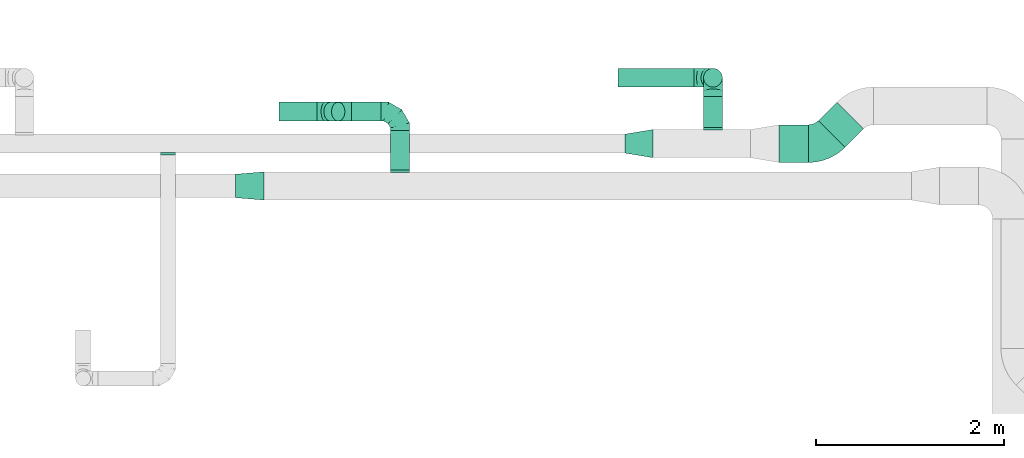
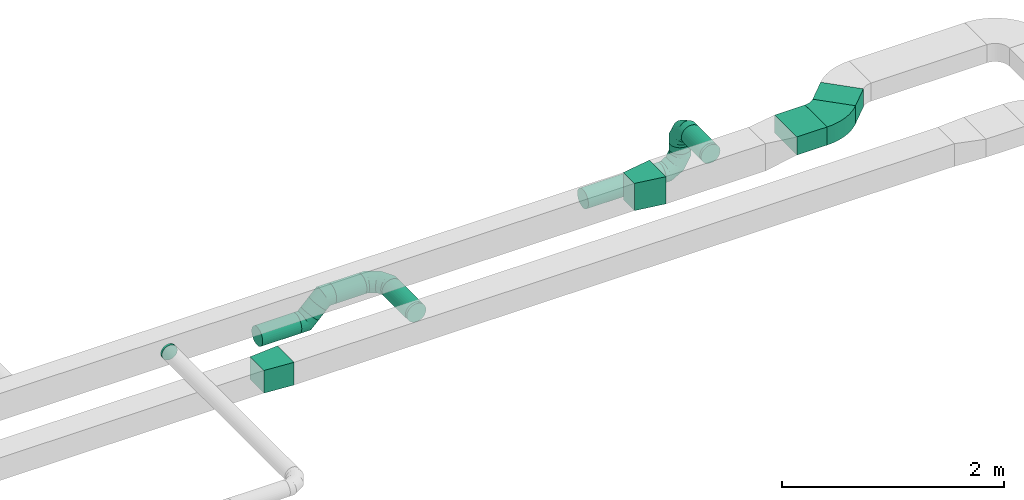
# One storey, part 47 of 60: 11 flow fittings, 9 flow segments.
"""IFC2X3 building model written with IfcOpenShell, lengths in millimetres."""

from ifc_helpers import new_model, entity, si_unit, converted_unit, derived_unit, direction, frame, frame_2d, origin, origin_2d_with_axis, place, context, subcontext, project, spatial, polyline, circle_curve, parameter, trimmed, segment, composite_curve, rectangle, circle, outline, extrude, faceted_brep, source, transform, mapped, material, type_object, type_shapes, element, save


model = new_model("IFC2X3")

# Units and contexts
model_context = context("Model", 3, precision=0.01, world=origin(), true_north=direction((6.12303176911189e-17, 1.0)))
body_context = subcontext(model_context, "Body", "Model", "MODEL_VIEW")
ifc_project = project(units=[si_unit("LENGTHUNIT", "METRE", prefix="MILLI"), si_unit("AREAUNIT", "SQUARE_METRE"), si_unit("VOLUMEUNIT", "CUBIC_METRE"), converted_unit("PLANEANGLEUNIT", "DEGREE", entity("IfcRatioMeasure", 0.0174532925199433), si_unit("PLANEANGLEUNIT", "RADIAN"), dimensions=[0, 0, 0, 0, 0, 0, 0]), si_unit("MASSUNIT", "GRAM", prefix="KILO"), derived_unit("MASSDENSITYUNIT", [(si_unit("MASSUNIT", "GRAM", prefix="KILO"), 1), (si_unit("LENGTHUNIT", "METRE"), -3)]), derived_unit("MOMENTOFINERTIAUNIT", [(si_unit("LENGTHUNIT", "METRE"), 4)]), si_unit("TIMEUNIT", "SECOND"), si_unit("FREQUENCYUNIT", "HERTZ"), si_unit("THERMODYNAMICTEMPERATUREUNIT", "DEGREE_CELSIUS"), derived_unit("THERMALTRANSMITTANCEUNIT", [(si_unit("MASSUNIT", "GRAM", prefix="KILO"), 1), (si_unit("THERMODYNAMICTEMPERATUREUNIT", "KELVIN"), -1), (si_unit("TIMEUNIT", "SECOND"), -3)]), derived_unit("VOLUMETRICFLOWRATEUNIT", [(si_unit("LENGTHUNIT", "METRE"), 3), (si_unit("TIMEUNIT", "SECOND"), -1)]), derived_unit("MASSFLOWRATEUNIT", [(si_unit("MASSUNIT", "GRAM", prefix="KILO"), 1), (si_unit("TIMEUNIT", "SECOND"), -1)]), derived_unit("ROTATIONALFREQUENCYUNIT", [(si_unit("TIMEUNIT", "SECOND"), -1)]), si_unit("ELECTRICCURRENTUNIT", "AMPERE"), si_unit("ELECTRICVOLTAGEUNIT", "VOLT"), si_unit("POWERUNIT", "WATT"), si_unit("FORCEUNIT", "NEWTON", prefix="KILO"), si_unit("ILLUMINANCEUNIT", "LUX"), si_unit("LUMINOUSFLUXUNIT", "LUMEN"), si_unit("LUMINOUSINTENSITYUNIT", "CANDELA"), derived_unit("USERDEFINED", [(si_unit("MASSUNIT", "GRAM", prefix="KILO"), -1), (si_unit("LENGTHUNIT", "METRE"), -2), (si_unit("TIMEUNIT", "SECOND"), 3), (si_unit("LUMINOUSFLUXUNIT", "LUMEN"), 1)]), derived_unit("LINEARVELOCITYUNIT", [(si_unit("LENGTHUNIT", "METRE"), 1), (si_unit("TIMEUNIT", "SECOND"), -1)]), si_unit("PRESSUREUNIT", "PASCAL"), derived_unit("USERDEFINED", [(si_unit("LENGTHUNIT", "METRE"), -2), (si_unit("MASSUNIT", "GRAM", prefix="KILO"), 1), (si_unit("TIMEUNIT", "SECOND"), -2)]), derived_unit("LINEARFORCEUNIT", [(si_unit("MASSUNIT", "GRAM", prefix="KILO"), 1), (si_unit("LENGTHUNIT", "METRE"), 1), (si_unit("TIMEUNIT", "SECOND"), -2), (si_unit("LENGTHUNIT", "METRE"), -1)]), derived_unit("PLANARFORCEUNIT", [(si_unit("MASSUNIT", "GRAM", prefix="KILO"), 1), (si_unit("LENGTHUNIT", "METRE"), 1), (si_unit("TIMEUNIT", "SECOND"), -2), (si_unit("LENGTHUNIT", "METRE"), -2)])], contexts=[model_context])

# Site, building, storey
site_placement = place(None, origin())
site = spatial("IfcSite", under=ifc_project, at=site_placement, CompositionType="ELEMENT")
building_placement = place(site_placement, origin())
building = spatial("IfcBuilding", under=site, at=building_placement, CompositionType="ELEMENT")
storey_placement = place(building_placement, frame((0.0, 0.0, 19800.0)))
storey = spatial("IfcBuildingStorey", under=building, at=storey_placement, CompositionType="ELEMENT", Elevation=19800.0)

# Flow segments
duct_segment_type_1 = type_object("IfcDuctSegmentType", PredefinedType="NOTDEFINED")
flow_segment_1_placement = place(storey_placement, frame((41004.79, 18161.27, 3550.0)))
element("IfcFlowSegment", 1, at=flow_segment_1_placement, inside=storey, type_object=duct_segment_type_1, context=body_context, shape_type="SweptSolid", body=[
    extrude(rectangle(XDim=276.237690674286, YDim=399.999999999994, at=origin_2d_with_axis()), frame((239.09, 239.09, 0.0), z_axis=(0.0, 0.0, 1.0), x_axis=(-0.707106781186497, -0.707106781186599, 0.0)), (0.0, 0.0, 1.0), 199.999999999998),
])
flow_segment_2_placement = place(storey_placement, frame((40583.7, 18000.18, 3550.0)))
element("IfcFlowSegment", 2, at=flow_segment_2_placement, inside=storey, type_object=duct_segment_type_1, context=body_context, shape_type="SweptSolid", body=[
    extrude(rectangle(XDim=315.025253169483, YDim=400.0, at=origin_2d_with_axis()), frame((157.51, 200.0, 0.0), z_axis=(0.0, 0.0, 1.0), x_axis=(-1.0, 0.0, 0.0)), (0.0, 0.0, 1.0), 199.999999999998),
])
duct_segment_type_2 = type_object("IfcDuctSegmentType", PredefinedType="NOTDEFINED")
flow_segment_3_placement = place(storey_placement, frame((36457.32, 17920.36, 3185.73)))
element("IfcFlowSegment", 3, at=flow_segment_3_placement, inside=storey, type_object=duct_segment_type_2, context=body_context, shape_type="SweptSolid", body=[
    extrude(circle(Radius=100.0, at=origin_2d_with_axis()), frame((101.6, 0.0, 101.6), z_axis=(0.0, 1.0, 0.0), x_axis=(1.0, 0.0, 0.0)), (0.0, 0.0, 1.0), 419.999999999972),
])
flow_segment_4_placement = place(storey_placement, frame((36044.08, 18438.76, 3185.73)))
element("IfcFlowSegment", 4, at=flow_segment_4_placement, inside=storey, type_object=duct_segment_type_2, context=body_context, shape_type="SweptSolid", body=[
    extrude(circle(Radius=100.0, at=origin_2d_with_axis()), frame((0.0, 101.6, 101.6), z_axis=(1.0, 0.0, 0.0), x_axis=(0.0, 1.0, 0.0)), (0.0, 0.0, 1.0), 314.831311316994),
])
flow_segment_5_placement = place(storey_placement, frame((35748.91, 18438.76, 3075.0)))
element("IfcFlowSegment", 5, at=flow_segment_5_placement, inside=storey, type_object=duct_segment_type_2, context=body_context, shape_type="SweptSolid", body=[
    extrude(circle(Radius=100.0, at=origin_2d_with_axis()), frame((72.31, 101.6, 72.31), z_axis=(0.707106781186548, 0.0, 0.707106781186548), x_axis=(0.0, 1.0, 0.0)), (0.0, 0.0, 1.0), 115.177595279234),
])
flow_segment_6_placement = place(storey_placement, frame((35272.64, 18438.76, 2987.13)))
element("IfcFlowSegment", 6, at=flow_segment_6_placement, inside=storey, type_object=duct_segment_type_2, context=body_context, shape_type="SweptSolid", body=[
    extrude(circle(Radius=100.0, at=origin_2d_with_axis()), frame((0.0, 101.6, 101.6), z_axis=(1.0, 0.0, 0.0), x_axis=(0.0, 1.0, 0.0)), (0.0, 0.0, 1.0), 407.157287525396),
])
flow_segment_7_placement = place(storey_placement, frame((39782.51, 18370.18, 3498.4)))
element("IfcFlowSegment", 7, at=flow_segment_7_placement, inside=storey, type_object=duct_segment_type_2, context=body_context, shape_type="SweptSolid", body=[
    extrude(circle(Radius=100.0, at=origin_2d_with_axis()), frame((101.6, 0.0, 101.6), z_axis=(0.0, 1.0, 0.0), x_axis=(1.0, 0.0, 0.0)), (0.0, 0.0, 1.0), 329.999999999994),
])
flow_segment_8_placement = place(storey_placement, frame((38874.11, 18798.59, 3023.4)))
element("IfcFlowSegment", 8, at=flow_segment_8_placement, inside=storey, type_object=duct_segment_type_2, context=body_context, shape_type="SweptSolid", body=[
    extrude(circle(Radius=100.0, at=origin_2d_with_axis()), frame((0.0, 101.6, 101.6), z_axis=(1.0, 0.0, 0.0), x_axis=(0.0, 1.0, 0.0)), (0.0, 0.0, 1.0), 810.000000000015),
])
flow_segment_9_placement = place(storey_placement, frame((39782.51, 18798.59, 3325.0)))
element("IfcFlowSegment", 9, at=flow_segment_9_placement, inside=storey, type_object=duct_segment_type_2, context=body_context, shape_type="SweptSolid", body=[
    extrude(circle(Radius=100.0, at=origin_2d_with_axis()), frame((101.6, 101.6, 0.0), z_axis=(0.0, 0.0, 1.0), x_axis=(0.0, 1.0, 0.0)), (0.0, 0.0, 1.0), 75.0000000000436),
])

# Flow fittings
ifc_material = material()
duct_fitting_type_1 = type_object("IfcDuctFittingType", PredefinedType="NOTDEFINED", material=ifc_material)
shared_shape_1 = source(origin(), body_context, "Body", "SweptSolid", [
    extrude(outline(polyline([(-161.94, -137.03), (139.1, -137.03), (159.86, 112.11), (-137.03, 161.94), (-161.94, -137.03)])), frame((150.0, 0.0, -125.0), z_axis=(0.0, 0.0, 1.0), x_axis=(0.99654575824488, 0.0830454798537381, 0.0)), (0.0, 0.0, 1.0), 250.0),
])
type_shapes(duct_fitting_type_1, [shared_shape_1])
flow_fitting_1_placement = place(storey_placement, frame((35113.67, 17750.36, 3300.0), z_axis=(0.0, 0.0, 1.0), x_axis=(-1.0, 0.0, 0.0)))
element("IfcFlowFitting", 10, at=flow_fitting_1_placement, inside=storey, type_object=duct_fitting_type_1, material=ifc_material, context=body_context, shape_type="MappedRepresentation", body=[
    mapped(shared_shape_1, transform((0.0, 0.0, 0.0), scale=1.0)),
])
duct_fitting_type_2 = type_object("IfcDuctFittingType", PredefinedType="NOTDEFINED", material=ifc_material)
shared_shape_2 = source(origin(), body_context, "Body", "SweptSolid", [
    extrude(outline(polyline([(-131.52, -123.3), (172.62, -123.3), (123.3, 172.62), (-164.4, 73.98), (-131.52, -123.3)])), frame((150.0, 0.0, -150.0), z_axis=(0.0, 0.0, 1.0), x_axis=(0.986393923832143, -0.164398987305359, 0.0)), (0.0, 0.0, 1.0), 300.0),
])
type_shapes(duct_fitting_type_2, [shared_shape_2])
flow_fitting_2_placement = place(storey_placement, frame((38948.07, 18200.18, 3600.0)))
element("IfcFlowFitting", 11, at=flow_fitting_2_placement, inside=storey, type_object=duct_fitting_type_2, material=ifc_material, context=body_context, shape_type="MappedRepresentation", body=[
    mapped(shared_shape_2, transform((0.0, 0.0, 0.0), scale=1.0)),
])
duct_fitting_type_3 = type_object("IfcDuctFittingType", PredefinedType="NOTDEFINED", material=ifc_material)
shared_shape_3 = source(origin(), body_context, "Body", "Brep", [
    faceted_brep([(-200.0, 0.0, -100.0), (-200.0, -25.88, -96.59), (-200.0, -50.0, -86.6), (-200.0, -70.71, -70.71), (-200.0, -86.6, -50.0), (-200.0, -96.59, -25.88), (-200.0, -100.0, 0.0), (-200.0, -96.59, 25.88), (-200.0, -86.6, 50.0), (-200.0, -70.71, 70.71), (-200.0, -50.0, 86.6), (-200.0, -25.88, 96.59), (-200.0, 0.0, 100.0), (-200.0, 25.88, 96.59), (-200.0, 50.0, 86.6), (-200.0, 70.71, 70.71), (-200.0, 86.6, 50.0), (-200.0, 96.59, 25.88), (-200.0, 100.0, 0.0), (-200.0, 96.59, -25.88), (-200.0, 86.6, -50.0), (-200.0, 70.71, -70.71), (-200.0, 50.0, -86.6), (-200.0, 25.88, -96.59), (-153.35, 25.88, 96.59), (-159.81, 50.0, 86.6), (-146.41, 0.0, 100.0), (-165.36, 70.71, 70.71), (-172.29, 96.59, 25.88), (-173.21, 100.0, 0.0), (-169.62, 86.6, 50.0), (-169.62, 86.6, -50.0), (-165.36, 70.71, -70.71), (-172.29, 96.59, -25.88), (-153.35, 25.88, -96.59), (-146.41, 0.0, -100.0), (-159.81, 50.0, -86.6), (-139.48, -25.88, -96.59), (-133.01, -50.0, -86.6), (-127.46, -70.71, -70.71), (-123.21, -86.6, -50.0), (-120.53, -96.59, -25.88), (-119.62, -100.0, 0.0), (-120.53, -96.59, 25.88), (-123.21, -86.6, 50.0), (-127.46, -70.71, 70.71), (-133.01, -50.0, 86.6), (-139.48, -25.88, 96.59), (-72.54, 72.54, 96.59), (-90.19, 90.19, 86.6), (-53.59, 53.59, 100.0), (-105.35, 105.35, 70.71), (-116.99, 116.99, 50.0), (-124.3, 124.3, 25.88), (-126.79, 126.79, 0.0), (-124.3, 124.3, -25.88), (-116.99, 116.99, -50.0), (-105.35, 105.35, -70.71), (-72.54, 72.54, -96.59), (-53.59, 53.59, -100.0), (-90.19, 90.19, -86.6), (-34.64, 34.64, -96.59), (-16.99, 16.99, -86.6), (-1.83, 1.83, -70.71), (9.81, -9.81, -50.0), (17.12, -17.12, -25.88), (19.62, -19.62, 0.0), (17.12, -17.12, 25.88), (9.81, -9.81, 50.0), (-1.83, 1.83, 70.71), (-16.99, 16.99, 86.6), (-34.64, 34.64, 96.59), (-25.88, 153.35, 96.59), (-50.0, 159.81, 86.6), (0.0, 146.41, 100.0), (-70.71, 165.36, 70.71), (-86.6, 169.62, 50.0), (-96.59, 172.29, 25.88), (-100.0, 173.21, 0.0), (-96.59, 172.29, -25.88), (-86.6, 169.62, -50.0), (-70.71, 165.36, -70.71), (-25.88, 153.35, -96.59), (0.0, 146.41, -100.0), (-50.0, 159.81, -86.6), (25.88, 139.48, -96.59), (50.0, 133.01, -86.6), (70.71, 127.46, -70.71), (86.6, 123.21, -50.0), (96.59, 120.53, -25.88), (100.0, 119.62, 0.0), (96.59, 120.53, 25.88), (86.6, 123.21, 50.0), (70.71, 127.46, 70.71), (50.0, 133.01, 86.6), (25.88, 139.48, 96.59), (-25.88, 200.0, -96.59), (-50.0, 200.0, -86.6), (-70.71, 200.0, -70.71), (-86.6, 200.0, -50.0), (-96.59, 200.0, -25.88), (-100.0, 200.0, 0.0), (-96.59, 200.0, 25.88), (-86.6, 200.0, 50.0), (-70.71, 200.0, 70.71), (-50.0, 200.0, 86.6), (-25.88, 200.0, 96.59), (0.0, 200.0, 100.0), (25.88, 200.0, 96.59), (50.0, 200.0, 86.6), (70.71, 200.0, 70.71), (86.6, 200.0, 50.0), (96.59, 200.0, 25.88), (100.0, 200.0, 0.0), (96.59, 200.0, -25.88), (86.6, 200.0, -50.0), (70.71, 200.0, -70.71), (50.0, 200.0, -86.6), (25.88, 200.0, -96.59), (0.0, 200.0, -100.0)], [[[0, 1, 2, 3, 4, 5, 6, 7, 8, 9, 10, 11, 12, 13, 14, 15, 16, 17, 18, 19, 20, 21, 22, 23]], [[24, 25, 14, 13]], [[26, 24, 13, 12]], [[14, 25, 27, 15]], [[28, 29, 18, 17]], [[30, 28, 17, 16]], [[15, 27, 30, 16]], [[20, 31, 32, 21]], [[33, 31, 20, 19]], [[18, 29, 33, 19]], [[34, 35, 0, 23]], [[36, 34, 23, 22]], [[32, 36, 22, 21]], [[1, 0, 35, 37]], [[2, 1, 37, 38]], [[38, 39, 3, 2]], [[5, 4, 40, 41]], [[6, 5, 41, 42]], [[39, 40, 4, 3]], [[6, 42, 43, 7]], [[7, 43, 44, 8]], [[8, 44, 45, 9]], [[9, 45, 46, 10]], [[10, 46, 47, 11]], [[26, 12, 11, 47]], [[48, 49, 25, 24]], [[50, 48, 24, 26]], [[27, 25, 49, 51]], [[52, 53, 28, 30]], [[51, 52, 30, 27]], [[29, 28, 53, 54]], [[55, 56, 31, 33]], [[54, 55, 33, 29]], [[32, 31, 56, 57]], [[58, 59, 35, 34]], [[60, 58, 34, 36]], [[57, 60, 36, 32]], [[37, 35, 59, 61]], [[38, 37, 61, 62]], [[39, 38, 62, 63]], [[41, 40, 64, 65]], [[42, 41, 65, 66]], [[63, 64, 40, 39]], [[43, 42, 66, 67]], [[44, 43, 67, 68]], [[68, 69, 45, 44]], [[46, 45, 69, 70]], [[47, 46, 70, 71]], [[26, 47, 71, 50]], [[72, 73, 49, 48]], [[74, 72, 48, 50]], [[51, 49, 73, 75]], [[76, 77, 53, 52]], [[75, 76, 52, 51]], [[54, 53, 77, 78]], [[79, 80, 56, 55]], [[78, 79, 55, 54]], [[57, 56, 80, 81]], [[82, 83, 59, 58]], [[84, 82, 58, 60]], [[81, 84, 60, 57]], [[61, 59, 83, 85]], [[62, 61, 85, 86]], [[63, 62, 86, 87]], [[65, 64, 88, 89]], [[66, 65, 89, 90]], [[87, 88, 64, 63]], [[67, 66, 90, 91]], [[68, 67, 91, 92]], [[92, 93, 69, 68]], [[70, 69, 93, 94]], [[71, 70, 94, 95]], [[50, 71, 95, 74]], [[96, 97, 98, 99, 100, 101, 102, 103, 104, 105, 106, 107, 108, 109, 110, 111, 112, 113, 114, 115, 116, 117, 118, 119]], [[72, 74, 107, 106]], [[73, 72, 106, 105]], [[75, 73, 105, 104]], [[102, 101, 78, 77]], [[103, 102, 77, 76]], [[75, 104, 103, 76]], [[78, 101, 100, 79]], [[79, 100, 99, 80]], [[80, 99, 98, 81]], [[84, 97, 96, 82]], [[82, 96, 119, 83]], [[84, 81, 98, 97]], [[118, 117, 86, 85]], [[119, 118, 85, 83]], [[116, 87, 86, 117]], [[88, 115, 114, 89]], [[89, 114, 113, 90]], [[115, 88, 87, 116]], [[91, 90, 113, 112]], [[92, 91, 112, 111]], [[111, 110, 93, 92]], [[95, 94, 109, 108]], [[74, 95, 108, 107]], [[110, 109, 94, 93]]]),
])
type_shapes(duct_fitting_type_3, [shared_shape_3])
for number, where, z_axis, x_axis in (
    (12, (36558.91, 18540.36, 3287.33), (0.0, 0.0, 1.0), (0.0, 1.0, 0.0)),
    (13, (39884.11, 18900.18, 3600.0), (-1.0, 0.0, 0.0), (0.0, 1.0, 0.0)),
    (14, (39884.11, 18900.18, 3125.0), (0.0, 1.0, 0.0), (0.0, 0.0, -1.0)),
):
    element("IfcFlowFitting", number, at=place(storey_placement, frame(where, z_axis=z_axis, x_axis=x_axis)), inside=storey, type_object=duct_fitting_type_3, material=ifc_material, context=body_context, shape_type="MappedRepresentation", body=[
        mapped(shared_shape_3, transform((0.0, 0.0, 0.0), scale=1.0)),
    ])
duct_fitting_type_4 = type_object("IfcDuctFittingType", PredefinedType="NOTDEFINED", material=ifc_material)
shared_shape_4 = source(origin(), body_context, "Body", "Brep", [
    faceted_brep([(20.0, 0.0, -80.0), (20.0, 20.71, -77.27), (20.0, 40.0, -69.28), (20.0, 56.57, -56.57), (20.0, 69.28, -40.0), (20.0, 77.27, -20.71), (20.0, 80.0, 0.0), (20.0, 77.27, 20.71), (20.0, 69.28, 40.0), (20.0, 56.57, 56.57), (20.0, 40.0, 69.28), (20.0, 20.71, 77.27), (20.0, 0.0, 80.0), (20.0, -20.71, 77.27), (20.0, -40.0, 69.28), (20.0, -56.57, 56.57), (20.0, -69.28, 40.0), (20.0, -77.27, 20.71), (20.0, -80.0, 0.0), (20.0, -77.27, -20.71), (20.0, -69.28, -40.0), (20.0, -56.57, -56.57), (20.0, -40.0, -69.28), (20.0, -20.71, -77.27), (0.0, 0.0, 80.0), (-6.1, 0.0, 80.0), (-6.1, -20.71, 77.27), (0.0, -20.71, 77.27), (-6.1, -40.0, 69.28), (0.0, -40.0, 69.28), (0.0, -56.57, 56.57), (-6.1, -56.57, 56.57), (0.0, -69.28, 40.0), (-6.1, -69.28, 40.0), (-6.1, -77.27, 20.71), (0.0, -77.27, 20.71), (-6.1, -80.0, 0.0), (0.0, -80.0, 0.0), (-6.1, -77.27, -20.71), (0.0, -77.27, -20.71), (-6.1, -69.28, -40.0), (0.0, -69.28, -40.0), (0.0, -56.57, -56.57), (-6.1, -56.57, -56.57), (0.0, -40.0, -69.28), (-6.1, -40.0, -69.28), (-6.1, -20.71, -77.27), (0.0, -20.71, -77.27), (-6.1, 0.0, -80.0), (0.0, 0.0, -80.0), (-6.1, 20.71, -77.27), (0.0, 20.71, -77.27), (-6.1, 40.0, -69.28), (0.0, 40.0, -69.28), (0.0, 56.57, -56.57), (-6.1, 56.57, -56.57), (0.0, 69.28, -40.0), (-6.1, 69.28, -40.0), (-6.1, 77.27, -20.71), (0.0, 77.27, -20.71), (-6.1, 80.0, 0.0), (0.0, 80.0, 0.0), (-6.1, 77.27, 20.71), (0.0, 77.27, 20.71), (-6.1, 69.28, 40.0), (0.0, 69.28, 40.0), (0.0, 56.57, 56.57), (-6.1, 56.57, 56.57), (0.0, 40.0, 69.28), (-6.1, 40.0, 69.28), (-6.1, 20.71, 77.27), (0.0, 20.71, 77.27)], [[[0, 1, 2, 3, 4, 5, 6, 7, 8, 9, 10, 11, 12, 13, 14, 15, 16, 17, 18, 19, 20, 21, 22, 23]], [[13, 12, 24, 25, 26, 27]], [[14, 13, 27, 26, 28, 29]], [[30, 15, 14, 29, 28, 31]], [[17, 16, 32, 33, 34, 35]], [[18, 17, 35, 34, 36, 37]], [[32, 16, 15, 30, 31, 33]], [[19, 18, 37, 36, 38, 39]], [[20, 19, 39, 38, 40, 41]], [[42, 21, 20, 41, 40, 43]], [[23, 22, 44, 45, 46, 47]], [[0, 23, 47, 46, 48, 49]], [[44, 22, 21, 42, 43, 45]], [[1, 0, 49, 48, 50, 51]], [[2, 1, 51, 50, 52, 53]], [[54, 3, 2, 53, 52, 55]], [[5, 4, 56, 57, 58, 59]], [[6, 5, 59, 58, 60, 61]], [[56, 4, 3, 54, 55, 57]], [[7, 6, 61, 60, 62, 63]], [[8, 7, 63, 62, 64, 65]], [[66, 9, 8, 65, 64, 67]], [[11, 10, 68, 69, 70, 71]], [[12, 11, 71, 70, 25, 24]], [[68, 10, 9, 66, 67, 69]], [[46, 45, 43, 40, 38, 36, 34, 33, 31, 28, 26, 25, 70, 69, 67, 64, 62, 60, 58, 57, 55, 52, 50, 48]]]),
])
type_shapes(duct_fitting_type_4, [shared_shape_4])
flow_fitting_3_placement = place(storey_placement, frame((34095.57, 18100.18, 3600.0), z_axis=(0.0, 0.0, -1.0), x_axis=(0.0, -1.0, 0.0)))
element("IfcFlowFitting", 15, at=flow_fitting_3_placement, inside=storey, type_object=duct_fitting_type_4, material=ifc_material, context=body_context, shape_type="MappedRepresentation", body=[
    mapped(shared_shape_4, transform((0.0, 0.0, 0.0), scale=1.0)),
])
duct_fitting_type_5 = type_object("IfcDuctFittingType", PredefinedType="NOTDEFINED", material=ifc_material)
shared_shape_5 = source(origin(), body_context, "Body", "Brep", [
    faceted_brep([(-82.84, 0.0, -100.0), (-82.84, -25.88, -96.59), (-82.84, -50.0, -86.6), (-82.84, -70.71, -70.71), (-82.84, -86.6, -50.0), (-82.84, -96.59, -25.88), (-82.84, -100.0, 0.0), (-82.84, -96.59, 25.88), (-82.84, -86.6, 50.0), (-82.84, -70.71, 70.71), (-82.84, -50.0, 86.6), (-82.84, -25.88, 96.59), (-82.84, 0.0, 100.0), (-82.84, 25.88, 96.59), (-82.84, 50.0, 86.6), (-82.84, 70.71, 70.71), (-82.84, 86.6, 50.0), (-82.84, 96.59, 25.88), (-82.84, 100.0, 0.0), (-82.84, 96.59, -25.88), (-82.84, 86.6, -50.0), (-82.84, 70.71, -70.71), (-82.84, 50.0, -86.6), (-82.84, 25.88, -96.59), (-10.72, 25.88, 96.59), (-20.71, 50.0, 86.6), (0.0, 0.0, 100.0), (-29.29, 70.71, 70.71), (-35.87, 86.6, 50.0), (-40.01, 96.59, 25.88), (-41.42, 100.0, 0.0), (-40.01, 96.59, -25.88), (-35.87, 86.6, -50.0), (-29.29, 70.71, -70.71), (-10.72, 25.88, -96.59), (0.0, 0.0, -100.0), (-20.71, 50.0, -86.6), (10.72, -25.88, -96.59), (20.71, -50.0, -86.6), (29.29, -70.71, -70.71), (35.87, -86.6, -50.0), (40.01, -96.59, -25.88), (41.42, -100.0, 0.0), (40.01, -96.59, 25.88), (35.87, -86.6, 50.0), (29.29, -70.71, 70.71), (20.71, -50.0, 86.6), (10.72, -25.88, 96.59), (58.58, 58.58, 100.0), (40.28, 76.88, 96.59), (23.22, 93.93, 86.6), (8.58, 108.58, 70.71), (-2.66, 119.82, 50.0), (-9.72, 126.88, 25.88), (-12.13, 129.29, 0.0), (-9.72, 126.88, -25.88), (-2.66, 119.82, -50.0), (8.58, 108.58, -70.71), (23.22, 93.93, -86.6), (40.28, 76.88, -96.59), (58.58, 58.58, -100.0), (76.88, 40.28, -96.59), (93.93, 23.22, -86.6), (108.58, 8.58, -70.71), (119.82, -2.66, -50.0), (126.88, -9.72, -25.88), (129.29, -12.13, 0.0), (126.88, -9.72, 25.88), (119.82, -2.66, 50.0), (108.58, 8.58, 70.71), (93.93, 23.22, 86.6), (76.88, 40.28, 96.59)], [[[0, 1, 2, 3, 4, 5, 6, 7, 8, 9, 10, 11, 12, 13, 14, 15, 16, 17, 18, 19, 20, 21, 22, 23]], [[24, 25, 14, 13]], [[26, 24, 13, 12]], [[14, 25, 27, 15]], [[28, 29, 17, 16]], [[28, 16, 15, 27]], [[30, 18, 17, 29]], [[31, 32, 20, 19]], [[30, 31, 19, 18]], [[32, 33, 21, 20]], [[34, 35, 0, 23]], [[36, 34, 23, 22]], [[33, 36, 22, 21]], [[1, 0, 35, 37]], [[2, 1, 37, 38]], [[38, 39, 3, 2]], [[5, 4, 40, 41]], [[6, 5, 41, 42]], [[39, 40, 4, 3]], [[6, 42, 43, 7]], [[7, 43, 44, 8]], [[8, 44, 45, 9]], [[9, 45, 46, 10]], [[10, 46, 47, 11]], [[26, 12, 11, 47]], [[24, 26, 48, 49]], [[25, 24, 49, 50]], [[27, 25, 50, 51]], [[29, 28, 52, 53]], [[30, 29, 53, 54]], [[51, 52, 28, 27]], [[30, 54, 55, 31]], [[31, 55, 56, 32]], [[57, 33, 32, 56]], [[36, 58, 59, 34]], [[34, 59, 60, 35]], [[58, 36, 33, 57]], [[35, 60, 61, 37]], [[37, 61, 62, 38]], [[63, 39, 38, 62]], [[40, 64, 65, 41]], [[41, 65, 66, 42]], [[64, 40, 39, 63]], [[43, 42, 66, 67]], [[44, 43, 67, 68]], [[68, 69, 45, 44]], [[47, 46, 70, 71]], [[26, 47, 71, 48]], [[69, 70, 46, 45]], [[59, 58, 57, 56, 55, 54, 53, 52, 51, 50, 49, 48, 71, 70, 69, 68, 67, 66, 65, 64, 63, 62, 61, 60]]]),
])
type_shapes(duct_fitting_type_5, [shared_shape_5])
for number, where, z_axis, x_axis in (
    (16, (35961.24, 18540.36, 3287.33), (0.0, -1.0, 0.0), (-1.0, 0.0, 0.0)),
    (17, (35762.64, 18540.36, 3088.73), (0.0, 1.0, 0.0), (-0.70710678118652, 0.0, -0.707106781186575)),
):
    element("IfcFlowFitting", number, at=place(storey_placement, frame(where, z_axis=z_axis, x_axis=x_axis)), inside=storey, type_object=duct_fitting_type_5, material=ifc_material, context=body_context, shape_type="MappedRepresentation", body=[
        mapped(shared_shape_5, transform((0.0, 0.0, 0.0), scale=1.0)),
    ])
duct_fitting_type_6 = type_object("IfcDuctFittingType", PredefinedType="NOTDEFINED", material=ifc_material)
shared_shape_6 = source(origin(), body_context, "Body", "Brep", [
    faceted_brep([(20.0, 25.88, -96.59), (20.0, 50.0, -86.6), (20.0, 70.71, -70.71), (20.0, 86.6, -50.0), (20.0, 96.59, -25.88), (20.0, 100.0, 0.0), (20.0, 96.59, 25.88), (20.0, 86.6, 50.0), (20.0, 70.71, 70.71), (20.0, 50.0, 86.6), (20.0, 25.88, 96.59), (20.0, 0.0, 100.0), (20.0, -25.88, 96.59), (20.0, -50.0, 86.6), (20.0, -70.71, 70.71), (20.0, -86.6, 50.0), (20.0, -96.59, 25.88), (20.0, -100.0, 0.0), (20.0, -96.59, -25.88), (20.0, -86.6, -50.0), (20.0, -70.71, -70.71), (20.0, -50.0, -86.6), (20.0, -25.88, -96.59), (20.0, 0.0, -100.0), (0.0, 0.0, 100.0), (0.0, 25.88, 96.59), (-6.1, 25.88, 96.59), (-6.1, 0.0, 100.0), (0.0, 50.0, 86.6), (-6.1, 50.0, 86.6), (0.0, 70.71, 70.71), (-6.1, 70.71, 70.71), (0.0, 86.6, 50.0), (0.0, 96.59, 25.88), (-6.1, 96.59, 25.88), (-6.1, 86.6, 50.0), (0.0, 100.0, 0.0), (-6.1, 100.0, 0.0), (0.0, 96.59, -25.88), (-6.1, 96.59, -25.88), (0.0, 86.6, -50.0), (-6.1, 86.6, -50.0), (0.0, 70.71, -70.71), (-6.1, 70.71, -70.71), (0.0, 50.0, -86.6), (0.0, 25.88, -96.59), (-6.1, 25.88, -96.59), (-6.1, 50.0, -86.6), (0.0, 0.0, -100.0), (-6.1, 0.0, -100.0), (0.0, -25.88, -96.59), (-6.1, -25.88, -96.59), (0.0, -50.0, -86.6), (-6.1, -50.0, -86.6), (0.0, -70.71, -70.71), (-6.1, -70.71, -70.71), (0.0, -86.6, -50.0), (0.0, -96.59, -25.88), (-6.1, -96.59, -25.88), (-6.1, -86.6, -50.0), (0.0, -100.0, 0.0), (-6.1, -100.0, 0.0), (0.0, -96.59, 25.88), (-6.1, -96.59, 25.88), (0.0, -86.6, 50.0), (-6.1, -86.6, 50.0), (0.0, -70.71, 70.71), (-6.1, -70.71, 70.71), (0.0, -50.0, 86.6), (0.0, -25.88, 96.59), (-6.1, -25.88, 96.59), (-6.1, -50.0, 86.6)], [[[0, 1, 2, 3, 4, 5, 6, 7, 8, 9, 10, 11, 12, 13, 14, 15, 16, 17, 18, 19, 20, 21, 22, 23]], [[24, 11, 10, 25, 26, 27]], [[25, 10, 9, 28, 29, 26]], [[28, 9, 8, 30, 31, 29]], [[32, 7, 6, 33, 34, 35]], [[33, 6, 5, 36, 37, 34]], [[30, 8, 7, 32, 35, 31]], [[36, 5, 4, 38, 39, 37]], [[38, 4, 3, 40, 41, 39]], [[40, 3, 2, 42, 43, 41]], [[44, 1, 0, 45, 46, 47]], [[45, 0, 23, 48, 49, 46]], [[42, 2, 1, 44, 47, 43]], [[48, 23, 22, 50, 51, 49]], [[50, 22, 21, 52, 53, 51]], [[52, 21, 20, 54, 55, 53]], [[56, 19, 18, 57, 58, 59]], [[57, 18, 17, 60, 61, 58]], [[54, 20, 19, 56, 59, 55]], [[60, 17, 16, 62, 63, 61]], [[62, 16, 15, 64, 65, 63]], [[64, 15, 14, 66, 67, 65]], [[68, 13, 12, 69, 70, 71]], [[69, 12, 11, 24, 27, 70]], [[66, 14, 13, 68, 71, 67]], [[49, 51, 53, 55, 59, 58, 61, 63, 65, 67, 71, 70, 27, 26, 29, 31, 35, 34, 37, 39, 41, 43, 47, 46]]]),
])
type_shapes(duct_fitting_type_6, [shared_shape_6])
flow_fitting_4_placement = place(storey_placement, frame((36558.91, 17900.36, 3287.33), z_axis=(0.0, 0.0, -1.0), x_axis=(0.0, 1.0, 0.0)))
element("IfcFlowFitting", 18, at=flow_fitting_4_placement, inside=storey, type_object=duct_fitting_type_6, material=ifc_material, context=body_context, shape_type="MappedRepresentation", body=[
    mapped(shared_shape_6, transform((0.0, 0.0, 0.0), scale=1.0)),
])
duct_fitting_type_7 = type_object("IfcDuctFittingType", PredefinedType="NOTDEFINED", material=ifc_material)
shared_shape_7 = source(origin(), body_context, "Body", "Brep", [
    faceted_brep([(20.0, 0.0, -100.0), (20.0, 25.88, -96.59), (20.0, 50.0, -86.6), (20.0, 70.71, -70.71), (20.0, 86.6, -50.0), (20.0, 96.59, -25.88), (20.0, 100.0, 0.0), (20.0, 96.59, 25.88), (20.0, 86.6, 50.0), (20.0, 70.71, 70.71), (20.0, 50.0, 86.6), (20.0, 25.88, 96.59), (20.0, 0.0, 100.0), (20.0, -25.88, 96.59), (20.0, -50.0, 86.6), (20.0, -70.71, 70.71), (20.0, -86.6, 50.0), (20.0, -96.59, 25.88), (20.0, -100.0, 0.0), (20.0, -96.59, -25.88), (20.0, -86.6, -50.0), (20.0, -70.71, -70.71), (20.0, -50.0, -86.6), (20.0, -25.88, -96.59), (0.0, 0.0, 100.0), (-6.1, 0.0, 100.0), (-6.1, -25.88, 96.59), (0.0, -25.88, 96.59), (-6.1, -50.0, 86.6), (0.0, -50.0, 86.6), (0.0, -70.71, 70.71), (-6.1, -70.71, 70.71), (0.0, -86.6, 50.0), (-6.1, -86.6, 50.0), (-6.1, -96.59, 25.88), (0.0, -96.59, 25.88), (-6.1, -100.0, 0.0), (0.0, -100.0, 0.0), (-6.1, -96.59, -25.88), (0.0, -96.59, -25.88), (-6.1, -86.6, -50.0), (0.0, -86.6, -50.0), (0.0, -70.71, -70.71), (-6.1, -70.71, -70.71), (0.0, -50.0, -86.6), (-6.1, -50.0, -86.6), (-6.1, -25.88, -96.59), (0.0, -25.88, -96.59), (-6.1, 0.0, -100.0), (0.0, 0.0, -100.0), (-6.1, 25.88, -96.59), (0.0, 25.88, -96.59), (-6.1, 50.0, -86.6), (0.0, 50.0, -86.6), (0.0, 70.71, -70.71), (-6.1, 70.71, -70.71), (0.0, 86.6, -50.0), (-6.1, 86.6, -50.0), (-6.1, 96.59, -25.88), (0.0, 96.59, -25.88), (-6.1, 100.0, 0.0), (0.0, 100.0, 0.0), (-6.1, 96.59, 25.88), (0.0, 96.59, 25.88), (-6.1, 86.6, 50.0), (0.0, 86.6, 50.0), (0.0, 70.71, 70.71), (-6.1, 70.71, 70.71), (0.0, 50.0, 86.6), (-6.1, 50.0, 86.6), (-6.1, 25.88, 96.59), (0.0, 25.88, 96.59)], [[[0, 1, 2, 3, 4, 5, 6, 7, 8, 9, 10, 11, 12, 13, 14, 15, 16, 17, 18, 19, 20, 21, 22, 23]], [[13, 12, 24, 25, 26, 27]], [[14, 13, 27, 26, 28, 29]], [[30, 15, 14, 29, 28, 31]], [[17, 16, 32, 33, 34, 35]], [[18, 17, 35, 34, 36, 37]], [[32, 16, 15, 30, 31, 33]], [[19, 18, 37, 36, 38, 39]], [[20, 19, 39, 38, 40, 41]], [[42, 21, 20, 41, 40, 43]], [[23, 22, 44, 45, 46, 47]], [[0, 23, 47, 46, 48, 49]], [[44, 22, 21, 42, 43, 45]], [[1, 0, 49, 48, 50, 51]], [[2, 1, 51, 50, 52, 53]], [[54, 3, 2, 53, 52, 55]], [[5, 4, 56, 57, 58, 59]], [[6, 5, 59, 58, 60, 61]], [[56, 4, 3, 54, 55, 57]], [[7, 6, 61, 60, 62, 63]], [[8, 7, 63, 62, 64, 65]], [[66, 9, 8, 65, 64, 67]], [[11, 10, 68, 69, 70, 71]], [[12, 11, 71, 70, 25, 24]], [[68, 10, 9, 66, 67, 69]], [[46, 45, 43, 40, 38, 36, 34, 33, 31, 28, 26, 25, 70, 69, 67, 64, 62, 60, 58, 57, 55, 52, 50, 48]]]),
])
type_shapes(duct_fitting_type_7, [shared_shape_7])
flow_fitting_5_placement = place(storey_placement, frame((39884.11, 18350.18, 3600.0), z_axis=(0.0, 0.0, -1.0), x_axis=(0.0, 1.0, 0.0)))
element("IfcFlowFitting", 19, at=flow_fitting_5_placement, inside=storey, type_object=duct_fitting_type_7, material=ifc_material, context=body_context, shape_type="MappedRepresentation", body=[
    mapped(shared_shape_7, transform((0.0, 0.0, 0.0), scale=1.0)),
])
duct_fitting_type_8 = type_object("IfcDuctFittingType", PredefinedType="NOTDEFINED", material=ifc_material)
shared_shape_8 = source(origin(), body_context, "Body", "SweptSolid", [
    extrude(outline(composite_curve([segment(polyline([(-251.26, -123.74), (148.74, -123.74)]), True, "CONTINUOUS"), segment(trimmed(circle_curve(frame_2d((298.74, -123.74), x_axis=(-0.707106781186546, 0.707106781186546)), 150.0), [parameter(0.0)], [parameter(45.0)], True, "PARAMETER"), False, "CONTINUOUS"), segment(polyline([(192.68, -17.68), (-90.17, 265.17)]), True, "CONTINUOUS"), segment(trimmed(circle_curve(frame_2d((298.74, -123.74), x_axis=(-0.707106781186546, 0.707106781186546)), 550.0), [parameter(0.0)], [parameter(45.0)], True, "PARAMETER"), True, "CONTINUOUS")], self_intersect=False)), frame((-21.23, 51.26, -100.0), z_axis=(0.0, 0.0, 1.0), x_axis=(-0.707106781186547, 0.707106781186548, 0.0)), (0.0, 0.0, 1.0), 200.0),
])
type_shapes(duct_fitting_type_8, [shared_shape_8])
flow_fitting_6_placement = place(storey_placement, frame((41043.7, 18200.18, 3650.0)))
element("IfcFlowFitting", 20, at=flow_fitting_6_placement, inside=storey, type_object=duct_fitting_type_8, material=ifc_material, context=body_context, shape_type="MappedRepresentation", body=[
    mapped(shared_shape_8, transform((0.0, 0.0, 0.0), scale=1.0)),
])

save(model, "model.ifc")
